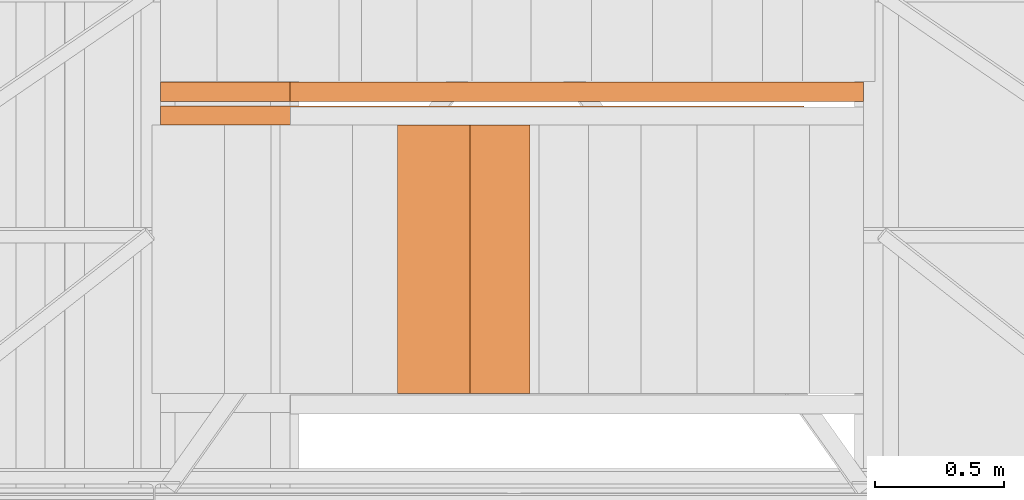
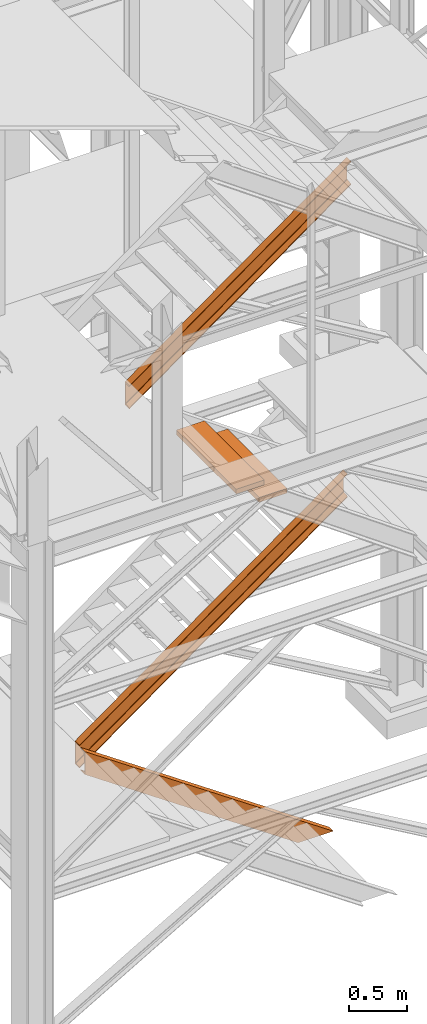
# One storey, part 45 of 208: 5 proxies.
"""IFC2X3 building model written with IfcOpenShell, lengths in millimetres."""

from ifc_helpers import new_model, entity, si_unit, converted_unit, frame, origin, origin_with_axes, place, context, subcontext, project, spatial, faceted_brep, element, save


model = new_model("IFC2X3")

# Units and contexts
model_context = context("Model", 3, precision=1e-05, world=origin())
plan_context = context("Plan", 3, precision=1e-05, world=origin())
body_context = subcontext(model_context, "Body", "Model", "MODEL_VIEW")
ifc_project = project(units=[si_unit("LENGTHUNIT", "METRE", prefix="MILLI"), converted_unit("PLANEANGLEUNIT", "DEGREE", entity("IfcPlaneAngleMeasure", 0.0174532925199433), si_unit("PLANEANGLEUNIT", "RADIAN"), dimensions=[0, 0, 0, 0, 0, 0, 0]), si_unit("AREAUNIT", "SQUARE_METRE"), si_unit("VOLUMEUNIT", "CUBIC_METRE")], contexts=[model_context, plan_context])

# Building, storey
building_placement = place(None, origin())
building = spatial("IfcBuilding", under=ifc_project, at=building_placement, CompositionType="COMPLEX")
storey_placement = place(building_placement, origin_with_axes())
storey = spatial("IfcBuildingStorey", under=building, at=storey_placement, Name="Geschoss", CompositionType="ELEMENT")

# Proxies
for number, where, z_axis, x_axis in (
    (1, (3722.013833371409, -24736.51916887601, 4518.103750398031), (0.0, 0.0, 1.0), (1.0, 0.0, 0.0)),
    (2, (3490.829763493463, -24736.51916887601, 4686.437984066917), (0.0, 0.0, 1.0), (1.0, 0.0, 0.0)),
):
    element("IfcBuildingElementProxy", number, at=place(storey_placement, frame(where, z_axis=z_axis, x_axis=x_axis)), inside=storey, context=body_context, shape_type="Brep", body=[
        faceted_brep([(0.01000000000021828, 0.00999999999839929, 0.01000000000021828), (280.2746556316183, 0.00999999999839929, 0.01000000000021828), (280.2746556316183, 1037.717170711916, 0.01000000000021828), (0.01000000000021828, 1037.717170711916, 0.01000000000021828), (280.2746556316183, 0.00999999999839929, 50.01000000000022), (0.01000000000021828, 0.00999999999839929, 50.01000000000022), (0.01000000000021828, 1037.717170711916, 50.01000000000022), (280.2746556316183, 1037.717170711916, 50.01000000000022), (280.2746556316183, 0.00999999999839929, 0.01000000000021828), (0.01000000000021828, 0.00999999999839929, 0.01000000000021828), (0.01000000000021828, 0.00999999999839929, 50.01000000000022), (280.2746556316183, 0.00999999999839929, 50.01000000000022), (280.2746556316183, 1037.717170711916, 0.01000000000021828), (280.2746556316183, 0.00999999999839929, 0.01000000000021828), (280.2746556316183, 0.00999999999839929, 50.01000000000022), (280.2746556316183, 1037.717170711916, 50.01000000000022), (0.01000000000021828, 1037.717170711916, 0.01000000000021828), (280.2746556316183, 1037.717170711916, 0.01000000000021828), (280.2746556316183, 1037.717170711916, 50.01000000000022), (0.01000000000021828, 1037.717170711916, 50.01000000000022), (0.01000000000021828, 0.00999999999839929, 0.01000000000021828), (0.01000000000021828, 1037.717170711916, 0.01000000000021828), (0.01000000000021828, 1037.717170711916, 50.01000000000022), (0.01000000000021828, 0.00999999999839929, 50.01000000000022)], [[[0, 1, 2, 3]], [[4, 5, 6, 7]], [[8, 9, 10, 11]], [[12, 13, 14, 15]], [[16, 17, 18, 19]], [[20, 21, 22, 23]]], orient=[[False], [False], [False], [False], [False], [False]]),
    ])
proxy_1_placement = place(storey_placement, frame((2573.108528797216, -23607.42795058644, 1416.268085031043), z_axis=(0.0, 0.0, 1.0), x_axis=(1.0, 0.0, 0.0)))
element("IfcBuildingElementProxy", 3, at=proxy_1_placement, inside=storey, context=body_context, shape_type="Brep", body=[
    faceted_brep([(0.01000000000112777, 75.01000111758549, 0.009999999999763531), (2685.302879462901, 75.01000111758549, 1934.948617654125), (2685.302879462901, 75.01000111758549, 2181.461873163844), (0.01000000000112777, 75.01000111758549, 246.5232555097173), (0.01000000000112777, 0.00999999999839929, 0.009999999999763531), (2685.302879462901, 0.00999999999839929, 1934.948617654125), (2685.302879462901, 75.01000111758549, 1934.948617654125), (0.01000000000112777, 75.01000111758549, 0.009999999999763531), (0.01000000000112777, 0.00999999999839929, 3.659420299631393), (2685.302879462901, 0.00999999999839929, 1938.598037953758), (2685.302879462901, 0.00999999999839929, 1934.948617654125), (0.01000000000112777, 0.00999999999839929, 0.009999999999763531), (0.01000000000203727, 1.126000115869829, 9.080250677066033), (2685.302879462901, 1.126000115869829, 1944.018868331192), (2685.302879462901, 0.00999999999839929, 1938.598037953758), (0.01000000000112777, 0.00999999999839929, 3.659420299631393), (0.01000000000112777, 5.531528422830888, 11.03126840622508), (2685.302879462901, 5.531528422830888, 1945.969886060354), (2685.302879462901, 1.126000115869829, 1944.018868331192), (0.01000000000203727, 1.126000115869829, 9.080250677066033), (0.01000000000112777, 55.92706931590874, 16.00053587166894), (2685.302879462901, 55.92706931590874, 1950.939153525795), (2685.302879462901, 5.531528422830888, 1945.969886060354), (0.01000000000112777, 5.531528422830888, 11.03126840622508), (0.01000000000112777, 61.66620032697756, 17.96675201902167), (2685.302879462901, 61.66620032697756, 1952.905369673148), (2685.302879462901, 55.92706931590874, 1950.939153525795), (0.01000000000112777, 55.92706931590874, 16.00053587166894), (0.01000000000203727, 65.51985109060843, 23.24250408189391), (2685.302879462901, 65.51985109060843, 1958.181121736021), (2685.302879462901, 61.66620032697756, 1952.905369673148), (0.01000000000112777, 61.66620032697756, 17.96675201902167), (0.01000000000021828, 66.51000065564949, 30.12990375652817), (2685.302879462901, 66.51000065564949, 1965.068521410655), (2685.302879462901, 65.51985109060843, 1958.181121736021), (0.01000000000203727, 65.51985109060843, 23.24250408189391), (0.01000000000112777, 66.51000065564949, 216.4033517531848), (2685.302879462901, 66.51000065564949, 2151.341969407311), (2685.302879462901, 66.51000065564949, 1965.068521410655), (0.01000000000021828, 66.51000065564949, 30.12990375652817), (0.01000000000112777, 65.51985109061206, 223.2907514278227), (2685.302879462901, 65.51985109060843, 2158.229369081949), (2685.302879462901, 66.51000065564949, 2151.341969407311), (0.01000000000112777, 66.51000065564949, 216.4033517531848), (0.01000000000112777, 61.66620032697756, 228.5665034906936), (2685.302879462901, 61.66620032697756, 2163.505121144821), (2685.302879462901, 65.51985109060843, 2158.229369081949), (0.01000000000112777, 65.51985109061206, 223.2907514278227), (0.01000000000112777, 55.92706931590874, 230.5327196380467), (2685.302879462901, 55.92706931590874, 2165.471337292173), (2685.302879462901, 61.66620032697756, 2163.505121144821), (0.01000000000112777, 61.66620032697756, 228.5665034906936), (0.01000000000112777, 5.531528422830888, 235.5019871034888), (2685.302879462901, 5.531528422830888, 2170.440604757615), (2685.302879462901, 55.92706931590874, 2165.471337292173), (0.01000000000112777, 55.92706931590874, 230.5327196380467), (0.01000000000112777, 1.126000115869829, 237.453004832651), (2685.302879462901, 1.126000115869829, 2172.391622486778), (2685.302879462901, 5.531528422830888, 2170.440604757615), (0.01000000000112777, 5.531528422830888, 235.5019871034888), (0.01000000000112777, 0.00999999999839929, 242.8738352100845), (2685.302879462901, 0.00999999999839929, 2177.812452864211), (2685.302879462901, 1.126000115869829, 2172.391622486778), (0.01000000000112777, 1.126000115869829, 237.453004832651), (0.01000000000112777, 0.00999999999839929, 246.5232555097171), (2685.302879462901, 0.00999999999839929, 2181.461873163844), (2685.302879462901, 0.00999999999839929, 2177.812452864211), (0.01000000000112777, 0.00999999999839929, 242.8738352100845), (0.01000000000112777, 75.01000111758549, 246.5232555097173), (2685.302879462901, 75.01000111758549, 2181.461873163844), (2685.302879462901, 0.00999999999839929, 2181.461873163844), (0.01000000000112777, 0.00999999999839929, 246.5232555097171), (2685.302879462901, 75.01000111758549, 1934.948617654125), (2685.302879462901, 0.00999999999839929, 1934.948617654125), (2685.302879462901, 0.00999999999839929, 1938.598037953758), (2685.302879462901, 1.126000115869829, 1944.018868331192), (2685.302879462901, 5.531528422830888, 1945.969886060354), (2685.302879462901, 55.92706931590874, 1950.939153525795), (2685.302879462901, 61.66620032697756, 1952.905369673148), (2685.302879462901, 65.51985109060843, 1958.181121736021), (2685.302879462901, 66.51000065564949, 1965.068521410655), (2685.302879462901, 66.51000065564949, 2151.341969407311), (2685.302879462901, 65.51985109060843, 2158.229369081949), (2685.302879462901, 61.66620032697756, 2163.505121144821), (2685.302879462901, 55.92706931590874, 2165.471337292173), (2685.302879462901, 5.531528422830888, 2170.440604757615), (2685.302879462901, 1.126000115869829, 2172.391622486778), (2685.302879462901, 0.00999999999839929, 2177.812452864211), (2685.302879462901, 0.00999999999839929, 2181.461873163844), (2685.302879462901, 75.01000111758549, 2181.461873163844), (0.01000000000112777, 75.01000111758549, 246.5232555097173), (0.01000000000112777, 0.00999999999839929, 246.5232555097171), (0.01000000000112777, 0.00999999999839929, 242.8738352100845), (0.01000000000112777, 1.126000115869829, 237.453004832651), (0.01000000000112777, 5.531528422830888, 235.5019871034888), (0.01000000000112777, 55.92706931590874, 230.5327196380467), (0.01000000000112777, 61.66620032697756, 228.5665034906936), (0.01000000000112777, 65.51985109061206, 223.2907514278227), (0.01000000000112777, 66.51000065564949, 216.4033517531848), (0.01000000000021828, 66.51000065564949, 30.12990375652817), (0.01000000000203727, 65.51985109060843, 23.24250408189391), (0.01000000000112777, 61.66620032697756, 17.96675201902167), (0.01000000000112777, 55.92706931590874, 16.00053587166894), (0.01000000000112777, 5.531528422830888, 11.03126840622508), (0.01000000000203727, 1.126000115869829, 9.080250677066033), (0.01000000000112777, 0.00999999999839929, 3.659420299631393), (0.01000000000112777, 0.00999999999839929, 0.009999999999763531), (0.01000000000112777, 75.01000111758549, 0.009999999999763531)], [[[0, 1, 2, 3]], [[4, 5, 6, 7]], [[8, 9, 10, 11]], [[12, 13, 14, 15]], [[16, 17, 18, 19]], [[20, 21, 22, 23]], [[24, 25, 26, 27]], [[28, 29, 30, 31]], [[32, 33, 34, 35]], [[36, 37, 38, 39]], [[40, 41, 42, 43]], [[44, 45, 46, 47]], [[48, 49, 50, 51]], [[52, 53, 54, 55]], [[56, 57, 58, 59]], [[60, 61, 62, 63]], [[64, 65, 66, 67]], [[68, 69, 70, 71]], [[72, 73, 74, 75, 76, 77, 78, 79, 80, 81, 82, 83, 84, 85, 86, 87, 88, 89]], [[90, 91, 92, 93, 94, 95, 96, 97, 98, 99, 100, 101, 102, 103, 104, 105, 106, 107]]], orient=[[False], [False], [False], [False], [False], [False], [False], [False], [False], [False], [False], [False], [False], [False], [False], [False], [False], [False], [False], [False]]),
])
proxy_2_placement = place(storey_placement, frame((2573.108528797216, -23698.81199816409, -65.01000000000045), z_axis=(0.0, 0.0, 1.0), x_axis=(1.0, 0.0, 0.0)))
element("IfcBuildingElementProxy", 4, at=proxy_2_placement, inside=storey, context=body_context, shape_type="Brep", body=[
    faceted_brep([(0.01000000000112777, 0.00999999999839929, 1472.287507638056), (0.01000000000112777, 0.00999999999839929, 1715.010001055714), (2490.156434367033, 0.00999999999839929, 0.01000000000044565), (2137.179805508645, 0.00999999999839929, 0.01000000000053092), (0.01000000000112777, 0.00999999999839929, 1715.010001055714), (0.01000000000112777, 75.01000111758549, 1715.010001055714), (2490.156434367033, 75.01000111758549, 0.01000000000044565), (2490.156434367033, 0.00999999999839929, 0.01000000000044565), (0.01000000000112777, 75.01000111758549, 1715.010001055714), (0.01000000000112777, 75.01000111758549, 1711.416699783438), (2484.930913848925, 75.01000111758549, 0.01000000000033197), (2490.156434367033, 75.01000111758549, 0.01000000000044565), (0.01000000000112777, 75.01000111758549, 1711.416699783438), (0.01000000000112777, 73.89400100171406, 1706.079228324208), (2477.168952212082, 73.89400100171406, 0.01000000000041723), (2484.930913848925, 75.01000111758549, 0.01000000000033197), (0.01000000000112777, 73.89400100171406, 1706.079228324208), (0.01000000000021828, 69.488472694753, 1704.158212405838), (2474.375335051584, 69.488472694753, 0.01000000000075829), (2477.168952212082, 73.89400100171406, 0.01000000000041723), (0.01000000000021828, 69.488472694753, 1704.158212405838), (0.01000000000112777, 19.09293180167515, 1699.265359941666), (2467.259955904038, 19.09293180167515, 0.01000000000058776), (2474.375335051584, 69.488472694753, 0.01000000000075829), (0.01000000000112777, 19.09293180167515, 1699.265359941666), (0.01000000000112777, 13.35380079060633, 1697.329379319055), (2464.444576480061, 13.35380079060633, 0.01000000000084356), (2467.259955904038, 19.09293180167515, 0.01000000000058776), (0.01000000000112777, 13.35380079060633, 1697.329379319055), (0.01000000000203727, 9.500150026975462, 1692.134755229952), (2456.890349126264, 9.500150026975462, 0.01000000000038881), (2464.444576480061, 13.35380079060633, 0.01000000000084356), (0.01000000000203727, 9.500150026975462, 1692.134755229952), (0.01000000000112777, 8.510000461934396, 1685.353266669694), (2447.02844083364, 8.510000461934396, 0.01000000000038881), (2456.890349126264, 9.500150026975462, 0.01000000000038881), (0.01000000000112777, 8.510000461934396, 1685.353266669694), (0.01000000000112777, 8.510000461934396, 1501.944242024078), (2180.307799042043, 8.510000461934396, 0.01000000000036039), (2447.02844083364, 8.510000461934396, 0.01000000000038881), (0.01000000000112777, 8.510000461934396, 1501.944242024078), (0.01000000000112777, 9.500150026975462, 1495.162753463817), (2170.445890749416, 9.500150026975462, 0.01000000000030354), (2180.307799042043, 8.510000461934396, 0.01000000000036039), (0.01000000000112777, 9.500150026975462, 1495.162753463817), (0.01000000000112777, 13.35380079060633, 1489.968129374717), (2162.891663395619, 13.35380079060633, 0.01000000000036039), (2170.445890749416, 9.500150026975462, 0.01000000000030354), (0.01000000000112777, 13.35380079060633, 1489.968129374717), (0.01000000000112777, 19.09293180167515, 1488.032148752105), (2160.076283971642, 19.09293180167515, 0.01000000000075829), (2162.891663395619, 13.35380079060633, 0.01000000000036039), (0.01000000000112777, 19.09293180167515, 1488.032148752105), (0.01000000000112777, 69.488472694753, 1483.139296287935), (2152.960904824097, 69.488472694753, 0.01000000000007617), (2160.076283971642, 19.09293180167515, 0.01000000000075829), (0.01000000000112777, 69.488472694753, 1483.139296287935), (0.01000000000112777, 73.89400100171406, 1481.218280369561), (2150.167287663598, 73.89400100171406, 0.01000000000007617), (2152.960904824097, 69.488472694753, 0.01000000000007617), (0.01000000000112777, 73.89400100171406, 1481.218280369561), (0.01000000000112777, 75.01000111758549, 1475.880808910333), (2142.405326026755, 75.01000111758549, 0.01000000000030354), (2150.167287663598, 73.89400100171406, 0.01000000000007617), (0.01000000000112777, 75.01000111758549, 1475.880808910333), (0.01000000000112777, 75.01000111758549, 1472.287507638056), (2137.179805508647, 75.01000111758549, 0.01000000000041723), (2142.405326026755, 75.01000111758549, 0.01000000000030354), (0.01000000000112777, 75.01000111758549, 1472.287507638056), (0.01000000000112777, 0.00999999999839929, 1472.287507638056), (2137.179805508645, 0.00999999999839929, 0.01000000000053092), (2137.179805508647, 75.01000111758549, 0.01000000000041723), (0.01000000000112777, 0.00999999999839929, 1715.010001055714), (0.01000000000112777, 0.00999999999839929, 1472.287507638056), (0.01000000000112777, 75.01000111758549, 1472.287507638056), (0.01000000000112777, 75.01000111758549, 1475.880808910333), (0.01000000000112777, 73.89400100171406, 1481.218280369561), (0.01000000000112777, 69.488472694753, 1483.139296287935), (0.01000000000112777, 19.09293180167515, 1488.032148752105), (0.01000000000112777, 13.35380079060633, 1489.968129374717), (0.01000000000112777, 9.500150026975462, 1495.162753463817), (0.01000000000112777, 8.510000461934396, 1501.944242024078), (0.01000000000112777, 8.510000461934396, 1685.353266669694), (0.01000000000203727, 9.500150026975462, 1692.134755229952), (0.01000000000112777, 13.35380079060633, 1697.329379319055), (0.01000000000112777, 19.09293180167515, 1699.265359941666), (0.01000000000021828, 69.488472694753, 1704.158212405838), (0.01000000000112777, 73.89400100171406, 1706.079228324208), (0.01000000000112777, 75.01000111758549, 1711.416699783438), (0.01000000000112777, 75.01000111758549, 1715.010001055714), (2137.179805508645, 0.00999999999839929, 0.01000000000053092), (2490.156434367033, 0.00999999999839929, 0.01000000000044565), (2490.156434367033, 75.01000111758549, 0.01000000000044565), (2484.930913848925, 75.01000111758549, 0.01000000000033197), (2477.168952212082, 73.89400100171406, 0.01000000000041723), (2474.375335051584, 69.488472694753, 0.01000000000075829), (2467.259955904038, 19.09293180167515, 0.01000000000058776), (2464.444576480061, 13.35380079060633, 0.01000000000084356), (2456.890349126264, 9.500150026975462, 0.01000000000038881), (2447.02844083364, 8.510000461934396, 0.01000000000038881), (2180.307799042043, 8.510000461934396, 0.01000000000036039), (2170.445890749416, 9.500150026975462, 0.01000000000030354), (2162.891663395619, 13.35380079060633, 0.01000000000036039), (2160.076283971642, 19.09293180167515, 0.01000000000075829), (2152.960904824097, 69.488472694753, 0.01000000000007617), (2150.167287663598, 73.89400100171406, 0.01000000000007617), (2142.405326026755, 75.01000111758549, 0.01000000000030354), (2137.179805508647, 75.01000111758549, 0.01000000000041723)], [[[0, 1, 2, 3]], [[4, 5, 6, 7]], [[8, 9, 10, 11]], [[12, 13, 14, 15]], [[16, 17, 18, 19]], [[20, 21, 22, 23]], [[24, 25, 26, 27]], [[28, 29, 30, 31]], [[32, 33, 34, 35]], [[36, 37, 38, 39]], [[40, 41, 42, 43]], [[44, 45, 46, 47]], [[48, 49, 50, 51]], [[52, 53, 54, 55]], [[56, 57, 58, 59]], [[60, 61, 62, 63]], [[64, 65, 66, 67]], [[68, 69, 70, 71]], [[72, 73, 74, 75, 76, 77, 78, 79, 80, 81, 82, 83, 84, 85, 86, 87, 88, 89]], [[90, 91, 92, 93, 94, 95, 96, 97, 98, 99, 100, 101, 102, 103, 104, 105, 106, 107]]], orient=[[False], [False], [False], [False], [False], [False], [False], [False], [False], [False], [False], [False], [False], [False], [False], [False], [False], [False], [False], [False]]),
])
proxy_3_placement = place(storey_placement, frame((3073.108528797206, -23607.42795058644, 5047.33263761315), z_axis=(0.0, 0.0, 1.0), x_axis=(1.0, 0.0, 0.0)))
element("IfcBuildingElementProxy", 5, at=proxy_3_placement, inside=storey, context=body_context, shape_type="Brep", body=[
    faceted_brep([(0.01000000000112777, 75.01000111759276, 0.009999999999308784), (2220.302879462909, 75.01000111758913, 1599.884065072019), (2220.30287946291, 75.01000111758913, 1846.397320581737), (0.01000000000112777, 75.01000111759276, 246.5232555097173), (0.01000000000112777, 0.01000000000567525, 0.009999999999308784), (2220.302879462909, 0.01000000000203727, 1599.884065072019), (2220.302879462909, 75.01000111758913, 1599.884065072019), (0.01000000000112777, 75.01000111759276, 0.009999999999308784), (0.01000000000112777, 0.01000000000567525, 3.659420299631165), (2220.30287946291, 0.01000000000203727, 1603.53348537165), (2220.302879462909, 0.01000000000203727, 1599.884065072019), (0.01000000000112777, 0.01000000000567525, 0.009999999999308784), (0.01000000000203727, 1.126000115877105, 9.080250677065123), (2220.30287946291, 1.126000115873467, 1608.954315749085), (2220.30287946291, 0.01000000000203727, 1603.53348537165), (0.01000000000112777, 0.01000000000567525, 3.659420299631165), (0.01000000000112777, 5.531528422838164, 11.03126840622463), (2220.30287946291, 5.531528422834526, 1610.905333478247), (2220.30287946291, 1.126000115873467, 1608.954315749085), (0.01000000000203727, 1.126000115877105, 9.080250677065123), (0.01000000000112777, 55.92706931591602, 16.00053587166804), (2220.30287946291, 55.92706931591238, 1615.874600943688), (2220.30287946291, 5.531528422834526, 1610.905333478247), (0.01000000000112777, 5.531528422838164, 11.03126840622463), (0.01000000000112777, 61.66620032698484, 17.96675201902144), (2220.30287946291, 61.6662003269812, 1617.840817091041), (2220.30287946291, 55.92706931591238, 1615.874600943688), (0.01000000000112777, 55.92706931591602, 16.00053587166804), (0.01000000000203727, 65.5198510906157, 23.24250408189346), (2220.30287946291, 65.51985109061206, 1623.116569153914), (2220.30287946291, 61.6662003269812, 1617.840817091041), (0.01000000000112777, 61.66620032698484, 17.96675201902144), (0.01000000000021828, 66.51000065565677, 30.12990375652771), (2220.302879462909, 66.51000065565313, 1630.003968828549), (2220.30287946291, 65.51985109061206, 1623.116569153914), (0.01000000000203727, 65.5198510906157, 23.24250408189346), (0.01000000000112777, 66.51000065565677, 216.4033517531843), (2220.30287946291, 66.51000065565313, 1816.277416825205), (2220.302879462909, 66.51000065565313, 1630.003968828549), (0.01000000000021828, 66.51000065565677, 30.12990375652771), (0.01000000000112777, 65.5198510906157, 223.2907514278222), (2220.302879462909, 65.51985109061206, 1823.164816499842), (2220.30287946291, 66.51000065565313, 1816.277416825205), (0.01000000000112777, 66.51000065565677, 216.4033517531843), (0.01000000000112777, 61.66620032698484, 228.5665034906933), (2220.302879462909, 61.6662003269812, 1828.440568562714), (2220.302879462909, 65.51985109061206, 1823.164816499842), (0.01000000000112777, 65.5198510906157, 223.2907514278222), (0.01000000000112777, 55.92706931591602, 230.5327196380458), (2220.30287946291, 55.92706931591238, 1830.406784710066), (2220.302879462909, 61.6662003269812, 1828.440568562714), (0.01000000000112777, 61.66620032698484, 228.5665034906933), (0.01000000000112777, 5.531528422838164, 235.5019871034883), (2220.30287946291, 5.531528422834526, 1835.376052175508), (2220.30287946291, 55.92706931591238, 1830.406784710066), (0.01000000000112777, 55.92706931591602, 230.5327196380458), (0.01000000000112777, 1.126000115877105, 237.4530048326506), (2220.30287946291, 1.126000115873467, 1837.327069904671), (2220.30287946291, 5.531528422834526, 1835.376052175508), (0.01000000000112777, 5.531528422838164, 235.5019871034883), (0.01000000000112777, 0.01000000000567525, 242.8738352100845), (2220.30287946291, 0.01000000000203727, 1842.747900282104), (2220.30287946291, 1.126000115873467, 1837.327069904671), (0.01000000000112777, 1.126000115877105, 237.4530048326506), (0.01000000000112777, 0.01000000000567525, 246.5232555097164), (2220.30287946291, 0.01000000000203727, 1846.397320581737), (2220.30287946291, 0.01000000000203727, 1842.747900282104), (0.01000000000112777, 0.01000000000567525, 242.8738352100845), (0.01000000000112777, 75.01000111759276, 246.5232555097173), (2220.30287946291, 75.01000111758913, 1846.397320581737), (2220.30287946291, 0.01000000000203727, 1846.397320581737), (0.01000000000112777, 0.01000000000567525, 246.5232555097164), (2220.302879462909, 75.01000111758913, 1599.884065072019), (2220.302879462909, 0.01000000000203727, 1599.884065072019), (2220.30287946291, 0.01000000000203727, 1603.53348537165), (2220.30287946291, 1.126000115873467, 1608.954315749085), (2220.30287946291, 5.531528422834526, 1610.905333478247), (2220.30287946291, 55.92706931591238, 1615.874600943688), (2220.30287946291, 61.6662003269812, 1617.840817091041), (2220.30287946291, 65.51985109061206, 1623.116569153914), (2220.302879462909, 66.51000065565313, 1630.003968828549), (2220.30287946291, 66.51000065565313, 1816.277416825205), (2220.302879462909, 65.51985109061206, 1823.164816499842), (2220.302879462909, 61.6662003269812, 1828.440568562714), (2220.30287946291, 55.92706931591238, 1830.406784710066), (2220.30287946291, 5.531528422834526, 1835.376052175508), (2220.30287946291, 1.126000115873467, 1837.327069904671), (2220.30287946291, 0.01000000000203727, 1842.747900282104), (2220.30287946291, 0.01000000000203727, 1846.397320581737), (2220.30287946291, 75.01000111758913, 1846.397320581737), (0.01000000000112777, 75.01000111759276, 246.5232555097173), (0.01000000000112777, 0.01000000000567525, 246.5232555097164), (0.01000000000112777, 0.01000000000567525, 242.8738352100845), (0.01000000000112777, 1.126000115877105, 237.4530048326506), (0.01000000000112777, 5.531528422838164, 235.5019871034883), (0.01000000000112777, 55.92706931591602, 230.5327196380458), (0.01000000000112777, 61.66620032698484, 228.5665034906933), (0.01000000000112777, 65.5198510906157, 223.2907514278222), (0.01000000000112777, 66.51000065565677, 216.4033517531843), (0.01000000000021828, 66.51000065565677, 30.12990375652771), (0.01000000000203727, 65.5198510906157, 23.24250408189346), (0.01000000000112777, 61.66620032698484, 17.96675201902144), (0.01000000000112777, 55.92706931591602, 16.00053587166804), (0.01000000000112777, 5.531528422838164, 11.03126840622463), (0.01000000000203727, 1.126000115877105, 9.080250677065123), (0.01000000000112777, 0.01000000000567525, 3.659420299631165), (0.01000000000112777, 0.01000000000567525, 0.009999999999308784), (0.01000000000112777, 75.01000111759276, 0.009999999999308784)], [[[0, 1, 2, 3]], [[4, 5, 6, 7]], [[8, 9, 10, 11]], [[12, 13, 14, 15]], [[16, 17, 18, 19]], [[20, 21, 22, 23]], [[24, 25, 26, 27]], [[28, 29, 30, 31]], [[32, 33, 34, 35]], [[36, 37, 38, 39]], [[40, 41, 42, 43]], [[44, 45, 46, 47]], [[48, 49, 50, 51]], [[52, 53, 54, 55]], [[56, 57, 58, 59]], [[60, 61, 62, 63]], [[64, 65, 66, 67]], [[68, 69, 70, 71]], [[72, 73, 74, 75, 76, 77, 78, 79, 80, 81, 82, 83, 84, 85, 86, 87, 88, 89]], [[90, 91, 92, 93, 94, 95, 96, 97, 98, 99, 100, 101, 102, 103, 104, 105, 106, 107]]], orient=[[False], [False], [False], [False], [False], [False], [False], [False], [False], [False], [False], [False], [False], [False], [False], [False], [False], [False], [False], [False]]),
])

save(model, "model.ifc")
